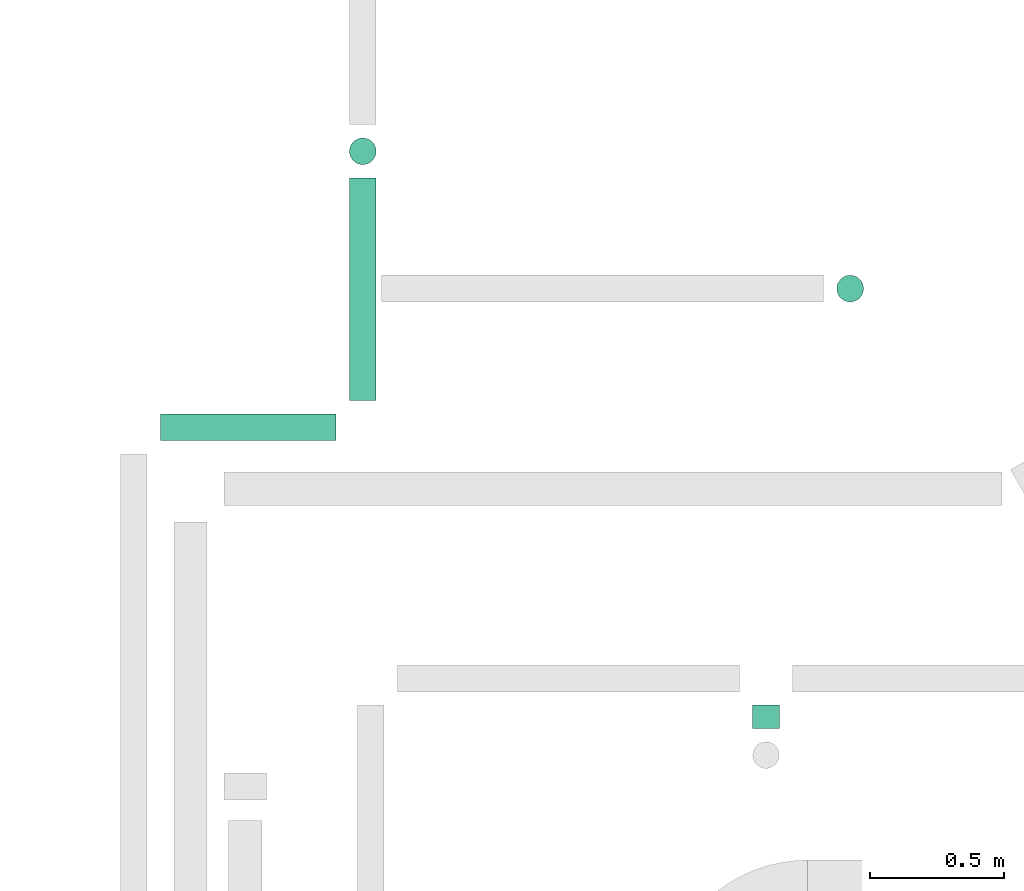
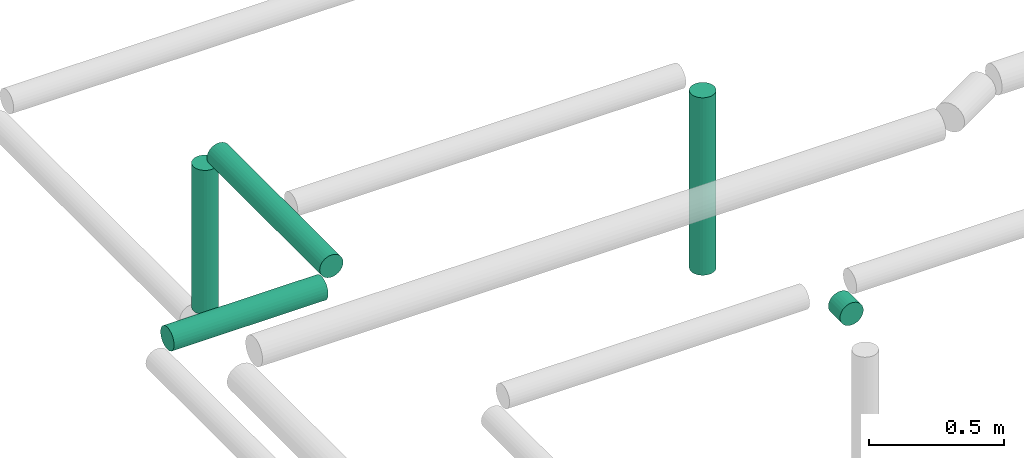
# One storey, part 296 of 337: 5 flow segments.
"""IFC2X3 building model written with IfcOpenShell, lengths in millimetres."""

from ifc_helpers import new_model, entity, si_unit, converted_unit, derived_unit, direction, frame, origin, origin_2d_with_axis, place, context, subcontext, project, spatial, circle, extrude, type_object, element, save


model = new_model("IFC2X3")

# Units and contexts
model_context = context("Model", 3, precision=0.01, world=origin(), true_north=direction((6.12303176911189e-17, 1.0)))
body_context = subcontext(model_context, "Body", "Model", "MODEL_VIEW")
ifc_project = project(units=[si_unit("LENGTHUNIT", "METRE", prefix="MILLI"), si_unit("AREAUNIT", "SQUARE_METRE"), si_unit("VOLUMEUNIT", "CUBIC_METRE"), converted_unit("PLANEANGLEUNIT", "DEGREE", entity("IfcRatioMeasure", 0.0174532925199433), si_unit("PLANEANGLEUNIT", "RADIAN"), dimensions=[0, 0, 0, 0, 0, 0, 0]), si_unit("MASSUNIT", "GRAM", prefix="KILO"), derived_unit("MASSDENSITYUNIT", [(si_unit("MASSUNIT", "GRAM", prefix="KILO"), 1), (si_unit("LENGTHUNIT", "METRE"), -3)]), derived_unit("MOMENTOFINERTIAUNIT", [(si_unit("LENGTHUNIT", "METRE"), 4)]), si_unit("TIMEUNIT", "SECOND"), si_unit("FREQUENCYUNIT", "HERTZ"), si_unit("THERMODYNAMICTEMPERATUREUNIT", "DEGREE_CELSIUS"), derived_unit("THERMALTRANSMITTANCEUNIT", [(si_unit("MASSUNIT", "GRAM", prefix="KILO"), 1), (si_unit("THERMODYNAMICTEMPERATUREUNIT", "KELVIN"), -1), (si_unit("TIMEUNIT", "SECOND"), -3)]), derived_unit("VOLUMETRICFLOWRATEUNIT", [(si_unit("LENGTHUNIT", "METRE"), 3), (si_unit("TIMEUNIT", "SECOND"), -1)]), derived_unit("MASSFLOWRATEUNIT", [(si_unit("MASSUNIT", "GRAM", prefix="KILO"), 1), (si_unit("TIMEUNIT", "SECOND"), -1)]), derived_unit("ROTATIONALFREQUENCYUNIT", [(si_unit("TIMEUNIT", "SECOND"), -1)]), si_unit("ELECTRICCURRENTUNIT", "AMPERE"), si_unit("ELECTRICVOLTAGEUNIT", "VOLT"), si_unit("POWERUNIT", "WATT"), si_unit("FORCEUNIT", "NEWTON", prefix="KILO"), si_unit("ILLUMINANCEUNIT", "LUX"), si_unit("LUMINOUSFLUXUNIT", "LUMEN"), si_unit("LUMINOUSINTENSITYUNIT", "CANDELA"), derived_unit("USERDEFINED", [(si_unit("MASSUNIT", "GRAM", prefix="KILO"), -1), (si_unit("LENGTHUNIT", "METRE"), -2), (si_unit("TIMEUNIT", "SECOND"), 3), (si_unit("LUMINOUSFLUXUNIT", "LUMEN"), 1)]), derived_unit("LINEARVELOCITYUNIT", [(si_unit("LENGTHUNIT", "METRE"), 1), (si_unit("TIMEUNIT", "SECOND"), -1)]), si_unit("PRESSUREUNIT", "PASCAL"), derived_unit("USERDEFINED", [(si_unit("LENGTHUNIT", "METRE"), -2), (si_unit("MASSUNIT", "GRAM", prefix="KILO"), 1), (si_unit("TIMEUNIT", "SECOND"), -2)]), derived_unit("LINEARFORCEUNIT", [(si_unit("MASSUNIT", "GRAM", prefix="KILO"), 1), (si_unit("LENGTHUNIT", "METRE"), 1), (si_unit("TIMEUNIT", "SECOND"), -2), (si_unit("LENGTHUNIT", "METRE"), -1)]), derived_unit("PLANARFORCEUNIT", [(si_unit("MASSUNIT", "GRAM", prefix="KILO"), 1), (si_unit("LENGTHUNIT", "METRE"), 1), (si_unit("TIMEUNIT", "SECOND"), -2), (si_unit("LENGTHUNIT", "METRE"), -2)])], contexts=[model_context])

# Site, building, storey
site_placement = place(None, origin())
site = spatial("IfcSite", under=ifc_project, at=site_placement, CompositionType="ELEMENT")
building_placement = place(site_placement, origin())
building = spatial("IfcBuilding", under=site, at=building_placement, CompositionType="ELEMENT")
storey_placement = place(building_placement, origin())
storey = spatial("IfcBuildingStorey", under=building, at=storey_placement, CompositionType="ELEMENT", Elevation=0.0)

# Flow segments
duct_segment_type = type_object("IfcDuctSegmentType", PredefinedType="NOTDEFINED")
flow_segment_1_placement = place(storey_placement, frame((67382.28, 18912.33, -951.6)))
element("IfcFlowSegment", 1, at=flow_segment_1_placement, inside=storey, type_object=duct_segment_type, context=body_context, shape_type="SweptSolid", body=[
    extrude(circle(Radius=50.0, at=origin_2d_with_axis()), frame((0.0, 51.6, 51.6), z_axis=(1.0, 0.0, 0.0), x_axis=(0.0, -1.0, 0.0)), (0.0, 0.0, 1.0), 657.099689999993),
])
flow_segment_2_placement = place(storey_placement, frame((68087.78, 19063.93, -951.6)))
element("IfcFlowSegment", 2, at=flow_segment_2_placement, inside=storey, type_object=duct_segment_type, context=body_context, shape_type="SweptSolid", body=[
    extrude(circle(Radius=50.0, at=origin_2d_with_axis()), frame((51.6, 0.0, 51.6), z_axis=(0.0, 1.0, 0.0), x_axis=(1.0, 0.0, 0.0)), (0.0, 0.0, 1.0), 833.181890000003),
])
flow_segment_3_placement = place(storey_placement, frame((69597.36, 17836.71, -951.6)))
element("IfcFlowSegment", 3, at=flow_segment_3_placement, inside=storey, type_object=duct_segment_type, context=body_context, shape_type="SweptSolid", body=[
    extrude(circle(Radius=50.0, at=origin_2d_with_axis()), frame((51.6, 0.0, 51.6), z_axis=(0.0, 1.0, 0.0), x_axis=(-1.0, 0.0, 0.0)), (0.0, 0.0, 1.0), 86.4260399999973),
])
flow_segment_4_placement = place(storey_placement, frame((69912.61, 19431.52, -1800.0)))
element("IfcFlowSegment", 4, at=flow_segment_4_placement, inside=storey, type_object=duct_segment_type, context=body_context, shape_type="SweptSolid", body=[
    extrude(circle(Radius=50.0, at=origin_2d_with_axis()), frame((51.6, 51.6, 0.0), z_axis=(0.0, 0.0, 1.0), x_axis=(0.0, -1.0, 0.0)), (0.0, 0.0, 1.0), 800.0),
])
flow_segment_5_placement = place(storey_placement, frame((68087.78, 19945.52, -1650.0)))
element("IfcFlowSegment", 5, at=flow_segment_5_placement, inside=storey, type_object=duct_segment_type, context=body_context, shape_type="SweptSolid", body=[
    extrude(circle(Radius=50.0, at=origin_2d_with_axis()), frame((51.6, 51.6, 0.0)), (0.0, 0.0, 1.0), 650.000000000008),
])

save(model, "model.ifc")
